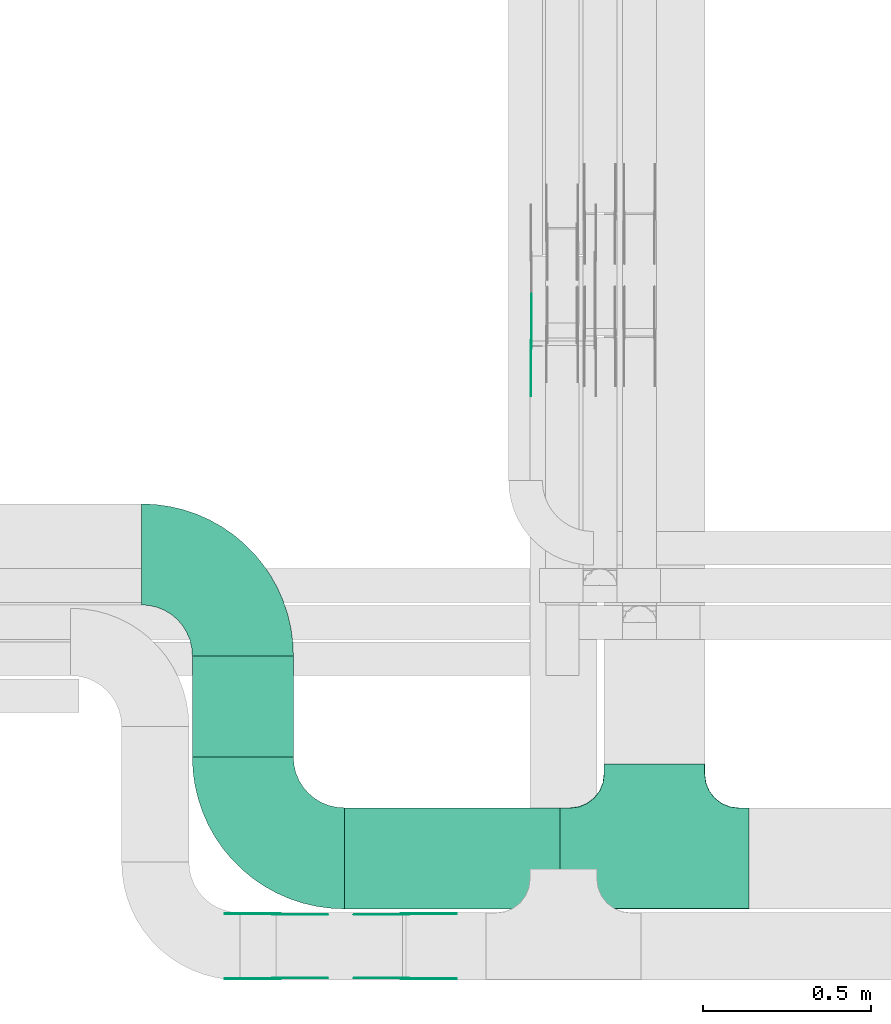
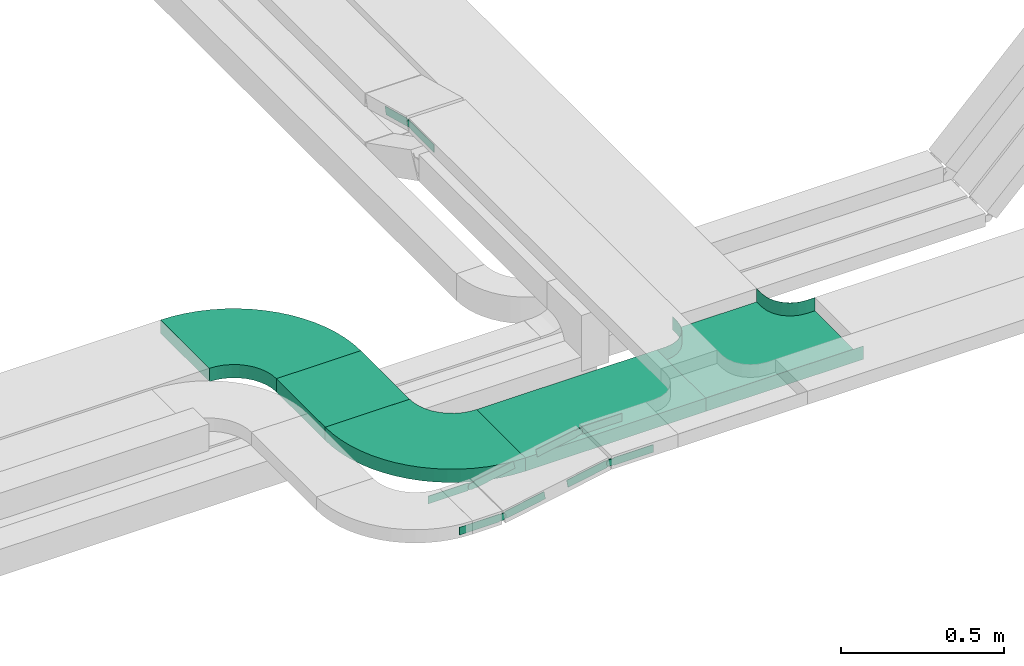
# One storey, part 13 of 19: 13 flow fittings, 2 flow segments.
"""IFC2X3 building model written with IfcOpenShell, lengths in millimetres."""

import ifcopenshell
import ifcopenshell.guid

model = None  # the IFC model being written
_history = None  # IfcOwnerHistory: only IFC2X3 demands one
_inside = {}  # id of a spatial element -> (the spatial element, [elements in it])
_under = {}  # id of a project, library or spatial element -> (it, [spatial elements below it])
_declared = {}  # id of a project -> (the project, [libraries it declares])
_typed = {}  # id of a type object -> (the type object, [elements of that type])
_made_of = {}  # id of a material, layer set ... -> (it, [elements and type objects made of it])


def new_model(schema):
    """Start an empty IFC model of exactly this schema.

    Asked for "IFC4X3", IfcOpenShell would pick the latest addendum, in which some entities
    have other attributes; the version numbers below select the first issue.
    IFC2X3 requires an IfcOwnerHistory on every rooted entity: one is made here for all.
    """
    global model, _history
    if schema == "IFC4X3":
        model = ifcopenshell.file(schema_version=(4, 3, 0, 0))
    else:
        model = ifcopenshell.file(schema=schema)
    _inside.clear()
    _under.clear()
    _declared.clear()
    _typed.clear()
    _made_of.clear()
    _history = None
    if model.schema == "IFC2X3":
        org = make("IfcOrganization", Name="unknown")
        user = make(
            "IfcPersonAndOrganization",
            ThePerson=make("IfcPerson", FamilyName="unknown"),
            TheOrganization=org,
        )
        app = make(
            "IfcApplication",
            ApplicationDeveloper=org,
            Version="unknown",
            ApplicationFullName="unknown",
            ApplicationIdentifier="unknown",
        )
        _history = make(
            "IfcOwnerHistory",
            OwningUser=user,
            OwningApplication=app,
            ChangeAction="ADDED",
            CreationDate=0,
        )
    return model


def make(cls, **values):
    """One entity of the class cls with the attributes given. An attribute that is None is left unset."""
    return model.create_entity(
        cls, **{name: value for name, value in values.items() if value is not None}
    )


def entity(cls, *values):
    """Any entity or typed value of the class cls, its attributes in the order of the schema. None: left unset."""
    e = model.create_entity(cls)
    for i, value in enumerate(values):
        if value is not None:
            e[i] = value
    return e


def rooted(cls, **values):
    """An entity with a GlobalId (a new one), such as an element, a storey or a relation."""
    return make(cls, GlobalId=ifcopenshell.guid.new(), OwnerHistory=_history, **values)


def si_unit(unit_type, name, prefix=None):
    """IfcSIUnit, for example si_unit("LENGTHUNIT", "METRE", prefix="MILLI")."""
    return make("IfcSIUnit", UnitType=unit_type, Prefix=prefix, Name=name)


def converted_unit(unit_type, name, factor, base, dimensions=None, offset=None):
    """IfcConversionBasedUnit, such as the inch: factor (a typed value) times the base unit."""
    return make(
        "IfcConversionBasedUnit"
        if offset is None
        else "IfcConversionBasedUnitWithOffset",
        ConversionOffset=offset,
        Dimensions=None
        if dimensions is None
        else entity("IfcDimensionalExponents", *dimensions),
        UnitType=unit_type,
        Name=name,
        ConversionFactor=make(
            "IfcMeasureWithUnit", ValueComponent=factor, UnitComponent=base
        ),
    )


def derived_unit(unit_type, elements):
    """IfcDerivedUnit: a product of units, each with its exponent."""
    return make(
        "IfcDerivedUnit",
        Elements=[
            make("IfcDerivedUnitElement", Unit=unit, Exponent=power)
            for unit, power in elements
        ],
        UnitType=unit_type,
    )


def assignment(units):
    """IfcUnitAssignment: the units of a project."""
    return None if units is None else make("IfcUnitAssignment", Units=units)


def point(xyz):
    """IfcCartesianPoint."""
    return None if xyz is None else make("IfcCartesianPoint", Coordinates=xyz)


def direction(xyz):
    """IfcDirection."""
    return None if xyz is None else make("IfcDirection", DirectionRatios=xyz)


def frame(location, z_axis=None, x_axis=None):
    """IfcAxis2Placement3D, a coordinate frame: its origin and axes. An axis left out is left unset."""
    return make(
        "IfcAxis2Placement3D",
        Location=point(location),
        Axis=direction(z_axis),
        RefDirection=direction(x_axis),
    )


def frame_2d(location, x_axis=None):
    """IfcAxis2Placement2D, a coordinate frame in the plane: its origin and x axis."""
    return make(
        "IfcAxis2Placement2D", Location=point(location), RefDirection=direction(x_axis)
    )


def origin():
    """The frame at (0, 0, 0) with its axes left unset."""
    return frame((0.0, 0.0, 0.0))


def origin_2d_with_axis():
    """The frame at (0, 0) in the plane with the x axis (1, 0) written out."""
    return frame_2d((0.0, 0.0), x_axis=(1.0, 0.0))


def place(relative_to, where):
    """IfcLocalPlacement: puts the frame where relative to a parent placement (None: the world)."""
    return make(
        "IfcLocalPlacement", PlacementRelTo=relative_to, RelativePlacement=where
    )


def context(
    kind, dimensions, precision=None, world=None, true_north=None, identifier=None
):
    """IfcGeometricRepresentationContext, for example the 3D "Model" context."""
    return make(
        "IfcGeometricRepresentationContext",
        ContextIdentifier=identifier,
        ContextType=kind,
        CoordinateSpaceDimension=dimensions,
        Precision=precision,
        WorldCoordinateSystem=world,
        TrueNorth=true_north,
    )


def subcontext(parent, identifier, kind, view, scale=None):
    """IfcGeometricRepresentationSubContext, for example "Body" below "Model"."""
    return make(
        "IfcGeometricRepresentationSubContext",
        ContextIdentifier=identifier,
        ContextType=kind,
        ParentContext=parent,
        TargetScale=scale,
        TargetView=view,
    )


def project(units=None, contexts=None):
    """IfcProject with its units and contexts."""
    return rooted(
        "IfcProject",
        Name="project",
        RepresentationContexts=contexts,
        UnitsInContext=assignment(units),
    )


def spatial(cls, under=None, at=None, **own):
    """A site, building, storey or space (cls), placed at a placement, below another one or the project."""
    s = rooted(cls, ObjectPlacement=at, **own)
    if under is not None:
        _under.setdefault(under.id(), (under, []))[1].append(s)
    return s


def polyline(points):
    """IfcPolyline through the points."""
    return make("IfcPolyline", Points=[point(p) for p in points])


def circle_curve(where, radius):
    """IfcCircle in the frame where."""
    return make("IfcCircle", Position=where, Radius=radius)


def parameter(value):
    """IfcParameterValue: where a trimmed curve begins or ends, as a parameter of its basis curve."""
    return model.create_entity("IfcParameterValue", value)


def trimmed(basis, trim1, trim2, sense, master):
    """IfcTrimmedCurve: the piece of a basis curve between two trims."""
    return make(
        "IfcTrimmedCurve",
        BasisCurve=basis,
        Trim1=trim1,
        Trim2=trim2,
        SenseAgreement=sense,
        MasterRepresentation=master,
    )


def segment(curve, same_sense, transition):
    """IfcCompositeCurveSegment."""
    return make(
        "IfcCompositeCurveSegment",
        Transition=transition,
        SameSense=same_sense,
        ParentCurve=curve,
    )


def composite_curve(segments, self_intersect=None):
    """IfcCompositeCurve: segments joined end to end."""
    return make("IfcCompositeCurve", Segments=segments, SelfIntersect=self_intersect)


def profile(cls, at=None, kind="AREA", **sizes):
    """A parametric profile (cls). Its sizes go by their IFC names, for example OverallWidth=200.0."""
    return make(cls, ProfileType=kind, Position=at, **sizes)


def rectangle(**sizes):
    """IfcRectangleProfileDef."""
    return profile("IfcRectangleProfileDef", **sizes)


def outline(outer, holes=None, kind="AREA"):
    """IfcArbitraryClosedProfileDef: a profile drawn as a closed curve; with holes, ...WithVoids."""
    if holes is None:
        return make("IfcArbitraryClosedProfileDef", ProfileType=kind, OuterCurve=outer)
    return make(
        "IfcArbitraryProfileDefWithVoids",
        ProfileType=kind,
        OuterCurve=outer,
        InnerCurves=holes,
    )


def extrude(swept, where, along, depth):
    """IfcExtrudedAreaSolid: the profile swept, set in the frame where, extruded along a direction by depth."""
    return make(
        "IfcExtrudedAreaSolid",
        SweptArea=swept,
        Position=where,
        ExtrudedDirection=direction(along),
        Depth=depth,
    )


def faces_of(points, faces, orient=None, outer=None):
    """IfcFace entities. A face is a list of loops; a loop is a list of indices into points, from 0.

    orient and outer hold one flag for each loop. By default every Orientation is true, the
    first loop of a face is its IfcFaceOuterBound and the others are IfcFaceBound.
    """
    made = []
    for i, loops in enumerate(faces):
        bounds = []
        for j, loop in enumerate(loops):
            is_outer = j == 0 if outer is None else outer[i][j]
            bounds.append(
                make(
                    "IfcFaceOuterBound" if is_outer else "IfcFaceBound",
                    Bound=make("IfcPolyLoop", Polygon=[points[k] for k in loop]),
                    Orientation=True if orient is None else orient[i][j],
                )
            )
        made.append(make("IfcFace", Bounds=bounds))
    return made


def faceted_brep(points, faces, orient=None, outer=None, voids=None):
    """IfcFacetedBrep: a solid bounded by flat faces; with voids (closed shells), ...WithVoids."""
    shared = [point(p) for p in points]
    hull = make("IfcClosedShell", CfsFaces=faces_of(shared, faces, orient, outer))
    if voids is None:
        return make("IfcFacetedBrep", Outer=hull)
    return make(
        "IfcFacetedBrepWithVoids",
        Outer=hull,
        Voids=[
            make(cls, CfsFaces=faces_of(shared, fs, o, b)) for cls, fs, o, b in voids
        ],
    )


def shape(context_of_items, identifier, shape_type, items):
    """IfcShapeRepresentation: the items that make up one representation, for example the "Body"."""
    return make(
        "IfcShapeRepresentation",
        ContextOfItems=context_of_items,
        RepresentationIdentifier=identifier,
        RepresentationType=shape_type,
        Items=items,
    )


def source(mapping_origin, context_of_items, identifier, shape_type, items):
    """IfcRepresentationMap: a shape defined once, which mapped items show again and again."""
    return make(
        "IfcRepresentationMap",
        MappingOrigin=mapping_origin,
        MappedRepresentation=shape(context_of_items, identifier, shape_type, items),
    )


def transform(
    local_origin,
    x_axis=None,
    y_axis=None,
    z_axis=None,
    scale=None,
    scale2=None,
    scale3=None,
    uniform=True,
):
    """IfcCartesianTransformationOperator3D, or its non-uniform kind. x_axis, y_axis, z_axis: its Axis1, 2, 3."""
    if uniform:
        return make(
            "IfcCartesianTransformationOperator3D",
            Axis1=direction(x_axis),
            Axis2=direction(y_axis),
            LocalOrigin=point(local_origin),
            Scale=scale,
            Axis3=direction(z_axis),
        )
    return make(
        "IfcCartesianTransformationOperator3DnonUniform",
        Axis1=direction(x_axis),
        Axis2=direction(y_axis),
        LocalOrigin=point(local_origin),
        Scale=scale,
        Axis3=direction(z_axis),
        Scale2=scale2,
        Scale3=scale3,
    )


def mapped(mapping_source, mapping_target):
    """IfcMappedItem: shows the shape of a source again, moved by a transform."""
    return make(
        "IfcMappedItem", MappingSource=mapping_source, MappingTarget=mapping_target
    )


def material(Name=None, Category=None):
    """IfcMaterial."""
    return make("IfcMaterial", Name=Name, Category=Category)


def made_of(thing, what):
    """Note that an element or type object is made of a material, layer set ...; save() writes the relation."""
    if what is not None:
        _made_of.setdefault(what.id(), (what, []))[1].append(thing)
    return thing


def type_object(cls, material=None, **own):
    """A type object (cls), such as IfcWallType, which elements share."""
    return made_of(rooted(cls, **own), material)


def type_shapes(of_type, sources):
    """Give a type object the sources (RepresentationMaps) that its elements show as mapped items."""
    of_type.RepresentationMaps = sources


def element(
    cls,
    number,
    at=None,
    inside=None,
    cuts=None,
    type_object=None,
    material=None,
    context=None,
    identifier="Body",
    shape_type=None,
    held_by="IfcProductDefinitionShape",
    body=None,
    shapes=None,
    **own,
):
    """One element of the class cls, such as IfcWall. Its Tag is "e" and its number.

    at: its placement. inside: the storey or other place that contains it. cuts: it is an
    opening in that element (IfcRelVoidsElement). A single representation is given by context,
    identifier, shape_type and body (its items); several are given by shapes. held_by: the class
    of the entity that holds the representations. save() writes the other relations.
    """
    e = rooted(cls, Tag="e%d" % number, ObjectPlacement=at, **own)
    if body is not None:
        shapes = [shape(context, identifier, shape_type, body)]
    if shapes is not None:
        e.Representation = make(held_by, Representations=shapes)
    if inside is not None:
        _inside.setdefault(inside.id(), (inside, []))[1].append(e)
    if cuts is not None:
        rooted(
            "IfcRelVoidsElement", RelatingBuildingElement=cuts, RelatedOpeningElement=e
        )
    if type_object is not None:
        _typed.setdefault(type_object.id(), (type_object, []))[1].append(e)
    return made_of(e, material)


def aggregate(whole, parts):
    """IfcRelAggregates: a whole, such as a stair, and the parts it consists of."""
    return rooted("IfcRelAggregates", RelatingObject=whole, RelatedObjects=parts)


def save(model, path):
    """Write the relations noted so far, then the file.

    IfcRelAggregates (storeys below a building ...), IfcRelContainedInSpatialStructure (elements
    in a storey), IfcRelDefinesByType, IfcRelAssociatesMaterial and IfcRelDeclares: one each for
    every whole, place, type object, material and project.
    """
    for whole, parts in _under.values():
        aggregate(whole, parts)
    for where, things in _inside.values():
        rooted(
            "IfcRelContainedInSpatialStructure",
            RelatedElements=things,
            RelatingStructure=where,
        )
    for kind, things in _typed.values():
        rooted("IfcRelDefinesByType", RelatedObjects=things, RelatingType=kind)
    for what, things in _made_of.values():
        rooted("IfcRelAssociatesMaterial", RelatedObjects=things, RelatingMaterial=what)
    for by, libraries in _declared.values():
        rooted("IfcRelDeclares", RelatingContext=by, RelatedDefinitions=libraries)
    model.write(path)


model = new_model("IFC2X3")

# Units and contexts
model_context = context("Model", 3, precision=0.01, world=origin(), true_north=direction((6.12303176911189e-17, 1.0)))
body_context = subcontext(model_context, "Body", "Model", "MODEL_VIEW")
ifc_project = project(units=[si_unit("LENGTHUNIT", "METRE", prefix="MILLI"), si_unit("AREAUNIT", "SQUARE_METRE"), si_unit("VOLUMEUNIT", "CUBIC_METRE"), converted_unit("PLANEANGLEUNIT", "DEGREE", entity("IfcRatioMeasure", 0.0174532925199433), si_unit("PLANEANGLEUNIT", "RADIAN"), dimensions=[0, 0, 0, 0, 0, 0, 0]), si_unit("MASSUNIT", "GRAM", prefix="KILO"), derived_unit("MASSDENSITYUNIT", [(si_unit("MASSUNIT", "GRAM", prefix="KILO"), 1), (si_unit("LENGTHUNIT", "METRE"), -3)]), derived_unit("MOMENTOFINERTIAUNIT", [(si_unit("LENGTHUNIT", "METRE"), 4)]), si_unit("TIMEUNIT", "SECOND"), si_unit("FREQUENCYUNIT", "HERTZ"), si_unit("THERMODYNAMICTEMPERATUREUNIT", "DEGREE_CELSIUS"), derived_unit("THERMALTRANSMITTANCEUNIT", [(si_unit("MASSUNIT", "GRAM", prefix="KILO"), 1), (si_unit("THERMODYNAMICTEMPERATUREUNIT", "KELVIN"), -1), (si_unit("TIMEUNIT", "SECOND"), -3)]), derived_unit("VOLUMETRICFLOWRATEUNIT", [(si_unit("LENGTHUNIT", "METRE"), 3), (si_unit("TIMEUNIT", "SECOND"), -1)]), derived_unit("MASSFLOWRATEUNIT", [(si_unit("MASSUNIT", "GRAM", prefix="KILO"), 1), (si_unit("TIMEUNIT", "SECOND"), -1)]), derived_unit("ROTATIONALFREQUENCYUNIT", [(si_unit("TIMEUNIT", "SECOND"), -1)]), si_unit("ELECTRICCURRENTUNIT", "AMPERE"), si_unit("ELECTRICVOLTAGEUNIT", "VOLT"), si_unit("POWERUNIT", "WATT"), si_unit("FORCEUNIT", "NEWTON", prefix="KILO"), si_unit("ILLUMINANCEUNIT", "LUX"), si_unit("LUMINOUSFLUXUNIT", "LUMEN"), si_unit("LUMINOUSINTENSITYUNIT", "CANDELA"), derived_unit("USERDEFINED", [(si_unit("MASSUNIT", "GRAM", prefix="KILO"), -1), (si_unit("LENGTHUNIT", "METRE"), -2), (si_unit("TIMEUNIT", "SECOND"), 3), (si_unit("LUMINOUSFLUXUNIT", "LUMEN"), 1)]), derived_unit("LINEARVELOCITYUNIT", [(si_unit("LENGTHUNIT", "METRE"), 1), (si_unit("TIMEUNIT", "SECOND"), -1)]), si_unit("PRESSUREUNIT", "PASCAL"), derived_unit("USERDEFINED", [(si_unit("LENGTHUNIT", "METRE"), -2), (si_unit("MASSUNIT", "GRAM", prefix="KILO"), 1), (si_unit("TIMEUNIT", "SECOND"), -2)]), derived_unit("LINEARFORCEUNIT", [(si_unit("MASSUNIT", "GRAM", prefix="KILO"), 1), (si_unit("LENGTHUNIT", "METRE"), 1), (si_unit("TIMEUNIT", "SECOND"), -2), (si_unit("LENGTHUNIT", "METRE"), -1)]), derived_unit("PLANARFORCEUNIT", [(si_unit("MASSUNIT", "GRAM", prefix="KILO"), 1), (si_unit("LENGTHUNIT", "METRE"), 1), (si_unit("TIMEUNIT", "SECOND"), -2), (si_unit("LENGTHUNIT", "METRE"), -2)])], contexts=[model_context])

# Site, building, storey
site_placement = place(None, frame((0.0, -0.00077364408347762, 0.0)))
site = spatial("IfcSite", under=ifc_project, at=site_placement, CompositionType="ELEMENT")
building_placement = place(site_placement, origin())
building = spatial("IfcBuilding", under=site, at=building_placement, CompositionType="ELEMENT")
storey_placement = place(building_placement, frame((0.0, 0.0, 12000.0)))
storey = spatial("IfcBuildingStorey", under=building, at=storey_placement, CompositionType="ELEMENT", Elevation=12000.0)

# Flow segments
cable_carrier_segment_type = type_object("IfcCableCarrierSegmentType", PredefinedType="CABLETRAYSEGMENT")
flow_segment_1_placement = place(storey_placement, frame((59541.892814939, 8824.98776832, 2800.0)))
element("IfcFlowSegment", 1, at=flow_segment_1_placement, inside=storey, type_object=cable_carrier_segment_type, context=body_context, shape_type="SweptSolid", body=[
    extrude(rectangle(XDim=640.660327660523, YDim=299.999999999999, at=frame_2d((-4.32009983342141e-12, -5.40012479177676e-13), x_axis=(1.0, 0.0))), frame((320.330163830257, 150.0, 0.0), z_axis=(0.0, 0.0, 1.0), x_axis=(-1.0, 0.0, 0.0)), (0.0, 0.0, 1.0), 50.0000000000016),
])
flow_segment_2_placement = place(storey_placement, frame((59090.892814939, 9275.98776831998, 2800.0)))
element("IfcFlowSegment", 2, at=flow_segment_2_placement, inside=storey, type_object=cable_carrier_segment_type, context=body_context, shape_type="SweptSolid", body=[
    extrude(rectangle(XDim=300.142155039271, YDim=300.000000000001, at=origin_2d_with_axis()), frame((150.0, 150.071077519653, 0.0), z_axis=(0.0, 0.0, 1.0), x_axis=(0.0, 1.0, 0.0)), (0.0, 0.0, 1.0), 50.0000000000016),
])

# Flow fittings
ifc_material_1 = material(Name="G")
cable_carrier_fitting_type_1 = type_object("IfcCableCarrierFittingType", PredefinedType="NOTDEFINED", material=ifc_material_1)
shared_shape_1 = source(origin(), body_context, "Body", "SweptSolid", [
    extrude(outline(composite_curve([segment(trimmed(circle_curve(frame_2d((-44.5901162790698, 0.0), x_axis=(1.0, 0.0)), 12.5), [parameter(90.0000000000007)], [parameter(270.0)], True, "PARAMETER"), True, "CONTINUOUS"), segment(polyline([(-44.5901162790697, -12.5), (-33.0901162790698, -12.5)]), True, "CONTINUOUS"), segment(polyline([(-33.0901162790698, -12.5), (-31.2296511627907, -14.5)]), True, "CONTINUOUS"), segment(polyline([(-31.2296511627907, -14.5), (108.90988372093, -14.5)]), True, "CONTINUOUS"), segment(polyline([(108.90988372093, -14.5), (108.90988372093, 14.5)]), True, "CONTINUOUS"), segment(polyline([(108.90988372093, 14.5), (-31.2296511627907, 14.5)]), True, "CONTINUOUS"), segment(polyline([(-31.2296511627907, 14.5), (-33.0901162790698, 12.5)]), True, "CONTINUOUS"), segment(polyline([(-33.0901162790698, 12.5), (-44.5901162790699, 12.5)]), True, "CONTINUOUS")], self_intersect=False)), frame((44.5901162790698, 0.0, 0.0), z_axis=(0.0, 0.0, -1.0), x_axis=(1.0, 0.0, 0.0)), (0.0, 0.0, -1.0), 2.0),
])
type_shapes(cable_carrier_fitting_type_1, [shared_shape_1])
for number, where, z_axis, x_axis in (
    (3, (59722.5531425995, 8809.27713291537, 2895.0), (0.0, 1.0, 0.0), (1.0, 0.0, 0.0)),
    (4, (59340.892814939, 8809.27713291537, 2825.0), (0.0, 1.0, 0.0), (-1.0, 0.0, 0.0)),
):
    element("IfcFlowFitting", number, at=place(storey_placement, frame(where, z_axis=z_axis, x_axis=x_axis)), inside=storey, type_object=cable_carrier_fitting_type_1, material=ifc_material_1, context=body_context, shape_type="MappedRepresentation", body=[
        mapped(shared_shape_1, transform((0.0, 0.0, 0.0), scale=1.0)),
    ])
cable_carrier_fitting_type_2 = type_object("IfcCableCarrierFittingType", PredefinedType="NOTDEFINED", material=ifc_material_1)
shared_shape_2 = source(origin(), body_context, "Body", "SweptSolid", [
    extrude(outline(composite_curve([segment(trimmed(circle_curve(frame_2d((-44.5901162790697, 0.0), x_axis=(1.0, 0.0)), 12.5), [parameter(90.0000000000007)], [parameter(270.0)], True, "PARAMETER"), True, "CONTINUOUS"), segment(polyline([(-44.5901162790697, -12.5), (-33.0901162790697, -12.5)]), True, "CONTINUOUS"), segment(polyline([(-33.0901162790697, -12.5), (-31.2296511627907, -14.5)]), True, "CONTINUOUS"), segment(polyline([(-31.2296511627907, -14.5), (108.90988372093, -14.5)]), True, "CONTINUOUS"), segment(polyline([(108.90988372093, -14.5), (108.90988372093, 14.5)]), True, "CONTINUOUS"), segment(polyline([(108.90988372093, 14.5), (-31.2296511627907, 14.5)]), True, "CONTINUOUS"), segment(polyline([(-31.2296511627907, 14.5), (-33.0901162790698, 12.5)]), True, "CONTINUOUS"), segment(polyline([(-33.0901162790698, 12.5), (-44.5901162790699, 12.5)]), True, "CONTINUOUS")], self_intersect=False)), frame((44.5901162790697, 0.0, 0.0)), (0.0, 0.0, 1.0), 2.0),
])
type_shapes(cable_carrier_fitting_type_2, [shared_shape_2])
for number, where, z_axis, x_axis in (
    (5, (60097.0931425894, 10499.7481729391, 2895.0), (-1.0, 0.0, 0.0), (0.0, -1.0, 0.0)),
    (6, (59722.5531425995, 8618.35713289505, 2895.0), (0.0, -1.0, 0.0), (1.0, 0.0, 0.0)),
    (7, (59340.892814939, 8618.35713289505, 2825.0), (0.0, -1.0, 0.0), (-1.0, 0.0, 0.0)),
):
    element("IfcFlowFitting", number, at=place(storey_placement, frame(where, z_axis=z_axis, x_axis=x_axis)), inside=storey, type_object=cable_carrier_fitting_type_2, material=ifc_material_1, context=body_context, shape_type="MappedRepresentation", body=[
        mapped(shared_shape_2, transform((0.0, 0.0, 0.0), scale=1.0)),
    ])
cable_carrier_fitting_type_3 = type_object("IfcCableCarrierFittingType", PredefinedType="NOTDEFINED", material=ifc_material_1)
shared_shape_3 = source(origin(), body_context, "Body", "SweptSolid", [
    extrude(outline(composite_curve([segment(trimmed(circle_curve(frame_2d((-44.5901162790698, 0.0), x_axis=(1.0, 0.0)), 12.5), [parameter(90.0000000000007)], [parameter(270.0)], True, "PARAMETER"), True, "CONTINUOUS"), segment(polyline([(-44.5901162790697, -12.5), (-33.0901162790698, -12.5)]), True, "CONTINUOUS"), segment(polyline([(-33.0901162790698, -12.5), (-31.2296511627907, -14.5)]), True, "CONTINUOUS"), segment(polyline([(-31.2296511627907, -14.5), (108.90988372093, -14.5)]), True, "CONTINUOUS"), segment(polyline([(108.90988372093, -14.5), (108.90988372093, 14.5)]), True, "CONTINUOUS"), segment(polyline([(108.90988372093, 14.5), (-31.2296511627907, 14.5)]), True, "CONTINUOUS"), segment(polyline([(-31.2296511627907, 14.5), (-33.0901162790698, 12.5)]), True, "CONTINUOUS"), segment(polyline([(-33.0901162790698, 12.5), (-44.5901162790699, 12.5)]), True, "CONTINUOUS")], self_intersect=False)), frame((44.5901162790698, 0.0, 0.0), z_axis=(0.0, 0.0, -1.0), x_axis=(1.0, 0.0, 0.0)), (0.0, 0.0, -1.0), 2.0),
])
type_shapes(cable_carrier_fitting_type_3, [shared_shape_3])
for number, where, z_axis, x_axis in (
    (8, (60099.0931425894, 10499.7481729391, 2895.0), (-1.0, 0.0, 0.0), (0.0, 0.965925826289068, -0.258819045102521)),
    (9, (59722.5531425995, 8620.35713289506, 2895.0), (0.0, -1.0, 0.0), (-0.983593325935759, 0.0, -0.180400025428576)),
    (10, (59340.892814939, 8620.35713289505, 2825.0), (0.0, -1.0, 0.0), (0.98359332593576, 0.0, 0.180400025428575)),
):
    element("IfcFlowFitting", number, at=place(storey_placement, frame(where, z_axis=z_axis, x_axis=x_axis)), inside=storey, type_object=cable_carrier_fitting_type_3, material=ifc_material_1, context=body_context, shape_type="MappedRepresentation", body=[
        mapped(shared_shape_3, transform((0.0, 0.0, 0.0), scale=1.0)),
    ])
cable_carrier_fitting_type_4 = type_object("IfcCableCarrierFittingType", PredefinedType="NOTDEFINED", material=ifc_material_1)
shared_shape_4 = source(origin(), body_context, "Body", "SweptSolid", [
    extrude(outline(composite_curve([segment(trimmed(circle_curve(frame_2d((-44.5901162790697, 0.0), x_axis=(1.0, 0.0)), 12.5), [parameter(90.0000000000007)], [parameter(270.0)], True, "PARAMETER"), True, "CONTINUOUS"), segment(polyline([(-44.5901162790697, -12.5), (-33.0901162790697, -12.5)]), True, "CONTINUOUS"), segment(polyline([(-33.0901162790697, -12.5), (-31.2296511627907, -14.5)]), True, "CONTINUOUS"), segment(polyline([(-31.2296511627907, -14.5), (108.90988372093, -14.5)]), True, "CONTINUOUS"), segment(polyline([(108.90988372093, -14.5), (108.90988372093, 14.5)]), True, "CONTINUOUS"), segment(polyline([(108.90988372093, 14.5), (-31.2296511627907, 14.5)]), True, "CONTINUOUS"), segment(polyline([(-31.2296511627907, 14.5), (-33.0901162790698, 12.5)]), True, "CONTINUOUS"), segment(polyline([(-33.0901162790698, 12.5), (-44.5901162790699, 12.5)]), True, "CONTINUOUS")], self_intersect=False)), frame((44.5901162790697, 0.0, 0.0)), (0.0, 0.0, 1.0), 2.0),
])
type_shapes(cable_carrier_fitting_type_4, [shared_shape_4])
for number, where, z_axis, x_axis in (
    (11, (59722.5531425995, 8807.27713291537, 2895.0), (0.0, 1.0, 0.0), (-0.983593325935759, 0.0, -0.180400025428576)),
    (12, (59340.892814939, 8807.27713291537, 2825.0), (0.0, 1.0, 0.0), (0.98359332593576, 0.0, 0.180400025428575)),
):
    element("IfcFlowFitting", number, at=place(storey_placement, frame(where, z_axis=z_axis, x_axis=x_axis)), inside=storey, type_object=cable_carrier_fitting_type_4, material=ifc_material_1, context=body_context, shape_type="MappedRepresentation", body=[
        mapped(shared_shape_4, transform((0.0, 0.0, 0.0), scale=1.0)),
    ])
ifc_material_2 = material()
cable_carrier_fitting_type_5 = type_object("IfcCableCarrierFittingType", PredefinedType="NOTDEFINED", material=ifc_material_2)
shared_shape_5 = source(origin(), body_context, "Body", "Brep", [
    faceted_brep([(-153.407417371086, -224.118095489753, 25.0), (-150.0, -250.0, 25.0), (-150.0, -280.0, 25.0), (-149.199999999993, -280.0, 25.0), (-149.199999999993, -250.0, 25.0), (-152.634676710055, -223.911040253671, 25.0), (-162.704639298522, -199.600000000004, 25.0), (-178.723636456391, -178.7236364564, 25.0), (-199.599999999996, -162.704639298532, 25.0), (-223.911040253663, -152.634676710066, 25.0), (-250.0, -149.200000000004, 25.0), (-280.0, -149.200000000004, 25.0), (-280.0, -150.0, 25.0), (-250.0, -150.0, 25.0), (-224.118095489745, -153.407417371099, 25.0), (-200.0, -163.397459621561, 25.0), (-179.28932188134, -179.289321881349, 25.0), (-163.39745962155, -200.0, 25.0), (280.0, -150.0, 25.0), (280.0, -149.200000000004, 25.0), (250.0, -149.200000000007, 25.0), (223.911040253719, -152.634676710068, 25.0), (199.600000000048, -162.704639298534, 25.0), (178.723636456437, -178.7236364564, 25.0), (162.70463929856, -199.600000000004, 25.0), (152.634676710083, -223.91104025367, 25.0), (149.200000000009, -250.0, 25.0), (149.200000000007, -280.0, 25.0), (150.0, -280.0, 25.0), (150.0, -250.0, 25.0), (153.407417371116, -224.118095489752, 25.0), (163.39745962159, -200.0, 25.0), (179.289321881388, -179.289321881351, 25.0), (200.0, -163.397459621564, 25.0), (224.118095489802, -153.407417371102, 25.0), (250.0, -150.0, 25.0), (280.0, 149.199999999995, 25.0), (280.0, 150.0, 25.0), (-280.0, 150.0, 25.0), (-280.0, 149.199999999995, 25.0), (-280.0, -150.0, -25.0), (-280.0, 150.0, -25.0), (280.0, 150.0, -25.0), (280.0, -150.0, -25.0), (250.0, -150.0, -25.0), (224.118095489802, -153.407417371102, -25.0), (200.0, -163.397459621564, -25.0), (179.289321881388, -179.289321881351, -25.0), (163.39745962159, -200.0, -25.0), (153.407417371116, -224.118095489752, -25.0), (150.0, -250.0, -25.0), (150.0, -280.0, -25.0), (-150.0, -280.0, -25.0), (-150.0, -250.0, -25.0), (-153.407417371086, -224.118095489753, -25.0), (-163.39745962155, -200.0, -25.0), (-179.28932188134, -179.289321881349, -25.0), (-200.0, -163.397459621561, -25.0), (-224.118095489745, -153.407417371099, -25.0), (-250.0, -150.0, -25.0), (-150.0, -250.0, -24.199999999986), (149.200000000007, -280.0, -24.199999999986), (-149.199999999993, -280.0, -24.199999999986), (-149.199999999993, -250.0, -24.199999999986), (-250.0, -149.200000000004, -24.199999999986), (-280.0, -149.200000000004, -24.199999999986), (280.0, -149.200000000004, -24.199999999986), (250.0, -149.200000000004, -24.199999999986), (-280.0, 149.199999999995, -24.199999999986), (-250.0, -150.0, -24.199999999986), (250.0, -150.0, -24.199999999986), (280.0, 149.199999999995, -24.199999999986), (149.200000000009, -250.0, -24.199999999986), (150.0, -250.0, -24.199999999986), (-223.911040253663, -152.634676710066, -24.199999999986), (-199.599999999996, -162.704639298532, -24.199999999986), (-178.723636456391, -178.7236364564, -24.199999999986), (-162.704639298522, -199.600000000004, -24.199999999986), (-152.634676710055, -223.911040253671, -24.199999999986), (152.634676710083, -223.911040253671, -24.199999999986), (162.70463929856, -199.600000000004, -24.199999999986), (178.723636456436, -178.723636456401, -24.199999999986), (199.600000000047, -162.704639298534, -24.199999999986), (223.911040253719, -152.634676710069, -24.199999999986)], [[[0, 1, 2, 3, 4, 5, 6, 7, 8, 9, 10, 11, 12, 13, 14, 15, 16, 17]], [[18, 19, 20, 21, 22, 23, 24, 25, 26, 27, 28, 29, 30, 31, 32, 33, 34, 35]], [[36, 37, 38, 39]], [[40, 41, 42, 43, 44, 45, 46, 47, 48, 49, 50, 51, 52, 53, 54, 55, 56, 57, 58, 59]], [[2, 1, 60, 53, 52]], [[3, 2, 52, 51, 28, 27, 61, 62]], [[4, 3, 62, 63]], [[11, 10, 64, 65]], [[20, 19, 66, 67]], [[39, 38, 41, 40, 12, 11, 65, 68]], [[13, 12, 40, 59, 69]], [[18, 35, 70, 44, 43]], [[19, 18, 43, 42, 37, 36, 71, 66]], [[27, 26, 72, 61]], [[29, 28, 51, 50, 73]], [[38, 37, 42, 41]], [[36, 39, 68, 71]], [[68, 65, 64, 74, 75, 76, 77, 78, 63, 62, 61, 72, 79, 80, 81, 82, 83, 67, 66, 71]], [[14, 13, 69, 59, 58]], [[58, 57, 15, 14]], [[15, 57, 56, 16]], [[0, 17, 55, 54]], [[0, 54, 53, 60, 1]], [[55, 17, 16, 56]], [[5, 4, 63, 78]], [[6, 5, 78, 77]], [[7, 6, 77, 76]], [[8, 7, 76, 75]], [[9, 8, 75, 74]], [[10, 9, 74, 64]], [[21, 20, 67, 83]], [[22, 21, 83, 82]], [[23, 22, 82, 81]], [[81, 80, 24, 23]], [[24, 80, 79, 25]], [[79, 72, 26, 25]], [[30, 29, 73, 50, 49]], [[31, 30, 49, 48]], [[31, 48, 47, 32]], [[33, 32, 47, 46]], [[45, 34, 33, 46]], [[34, 45, 44, 70, 35]]]),
])
type_shapes(cable_carrier_fitting_type_5, [shared_shape_5])
flow_fitting_placement = place(storey_placement, frame((60462.5531425996, 8974.98776832, 2825.0), z_axis=(0.0, 0.0, 1.0), x_axis=(-1.0, 0.0, 0.0)))
element("IfcFlowFitting", 13, at=flow_fitting_placement, inside=storey, type_object=cable_carrier_fitting_type_5, material=ifc_material_2, Name="470_DKC_S5_T", context=body_context, shape_type="MappedRepresentation", body=[
    mapped(shared_shape_5, transform((0.0, 0.0, 0.0), scale=1.0)),
])
cable_carrier_fitting_type_6 = type_object("IfcCableCarrierFittingType", Name="470_DKC_S5_Variable Angle Elbow 0-45:-", PredefinedType="NOTDEFINED", material=ifc_material_2)
shared_shape_6 = source(origin(), body_context, "Body", "SweptSolid", [
    extrude(outline(composite_curve([segment(polyline([(-150.749999999996, -300.250000000003), (-149.749999999994, -300.250000000003)]), True, "CONTINUOUS"), segment(trimmed(circle_curve(frame_2d((-149.750000000002, 149.749999999997), x_axis=(0.0, -1.0)), 450.0), [parameter(0.0)], [parameter(90.0000000000001)], True, "PARAMETER"), True, "CONTINUOUS"), segment(polyline([(300.249999999997, 149.750000000005), (300.249999999997, 150.750000000004)]), True, "CONTINUOUS"), segment(polyline([(300.249999999997, 150.750000000003), (0.249999999997449, 150.750000000002)]), True, "CONTINUOUS"), segment(polyline([(0.249999999997449, 150.750000000002), (0.249999999997438, 149.75)]), True, "CONTINUOUS"), segment(trimmed(circle_curve(frame_2d((-149.750000000002, 149.749999999997), x_axis=(0.0, -1.0)), 150.0), [parameter(0.0)], [parameter(90.0000000000001)], True, "PARAMETER"), False, "CONTINUOUS"), segment(polyline([(-149.749999999999, -0.250000000002818), (-150.750000000001, -0.250000000002835)]), True, "CONTINUOUS"), segment(polyline([(-150.750000000001, -0.250000000002835), (-150.749999999996, -300.250000000003)]), True, "CONTINUOUS")], self_intersect=False)), frame((-150.249999999991, 150.249999999992, -25.0)), (0.0, 0.0, 1.0), 49.9999999999974),
])
type_shapes(cable_carrier_fitting_type_6, [shared_shape_6])
for number, where, z_axis, x_axis, name in (
    (14, (59240.892814939, 8974.98776832001, 2825.0), (0.0, 0.0, 1.0), (0.0, -1.0, 0.0), "470_DKC_S5_Variable Angle Elbow 0-45:-"),
    (15, (59240.892814939, 9877.12992335925, 2825.0), (0.0, 0.0, 1.0), (0.0, 1.0, 0.0), "470_DKC_S5_Variable Angle Elbow 0-45:-"),
):
    element("IfcFlowFitting", number, at=place(storey_placement, frame(where, z_axis=z_axis, x_axis=x_axis)), inside=storey, type_object=cable_carrier_fitting_type_6, material=ifc_material_2, Name=name, ObjectType="470_DKC_S5_Variable Angle Elbow 0-45:-", context=body_context, shape_type="MappedRepresentation", body=[
        mapped(shared_shape_6, transform((0.0, 0.0, 0.0), scale=1.0)),
    ])

save(model, "model.ifc")
